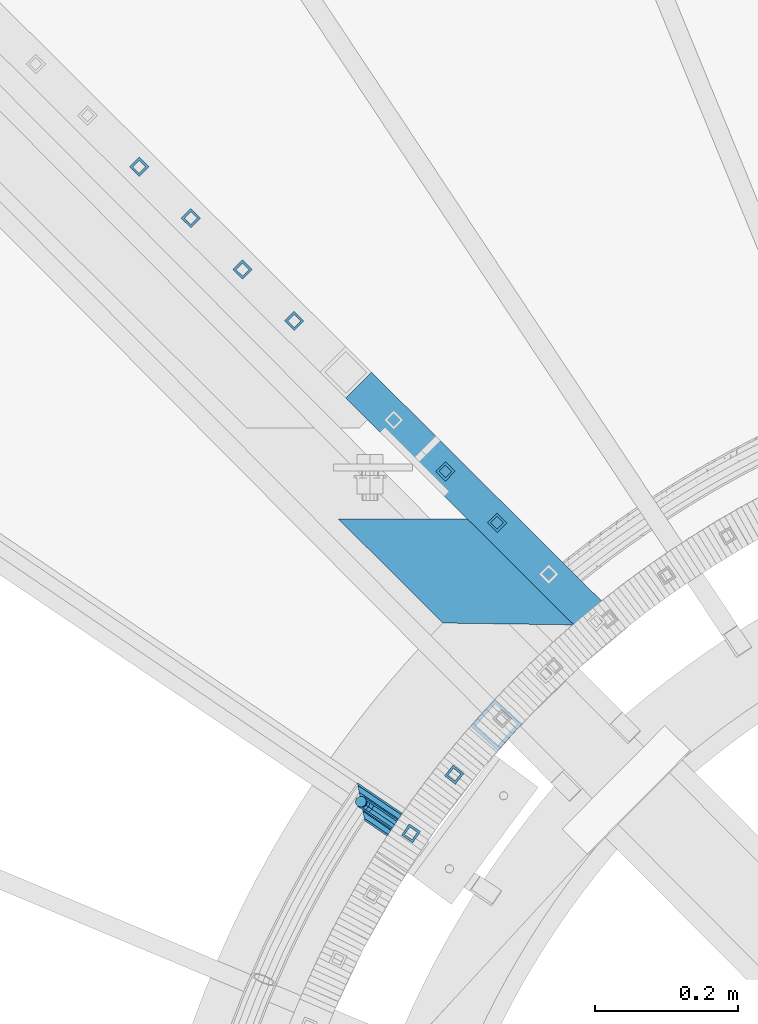
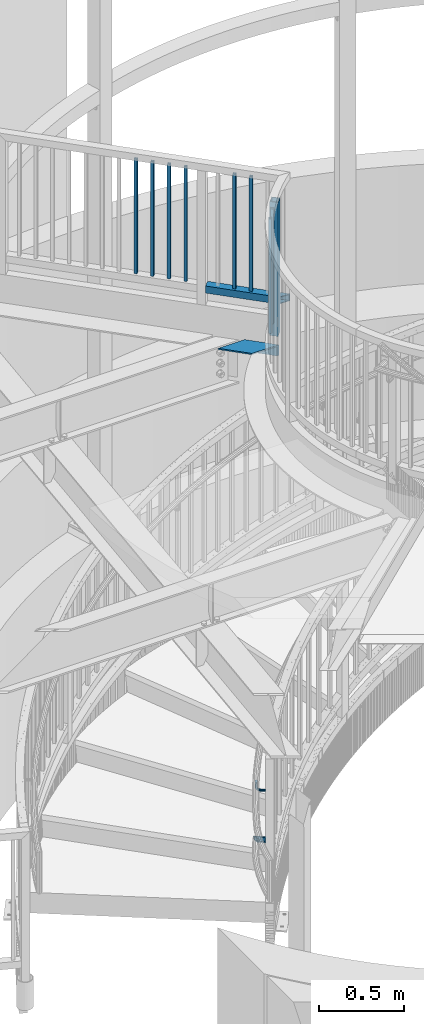
# One storey, part 482 of 975: 13 beams.
"""IFC2X3 building model written with IfcOpenShell, lengths in millimetres."""

import ifcopenshell
import ifcopenshell.guid

model = None  # the IFC model being written
_history = None  # IfcOwnerHistory: only IFC2X3 demands one
_inside = {}  # id of a spatial element -> (the spatial element, [elements in it])
_under = {}  # id of a project, library or spatial element -> (it, [spatial elements below it])
_declared = {}  # id of a project -> (the project, [libraries it declares])
_typed = {}  # id of a type object -> (the type object, [elements of that type])
_made_of = {}  # id of a material, layer set ... -> (it, [elements and type objects made of it])


def new_model(schema):
    """Start an empty IFC model of exactly this schema.

    Asked for "IFC4X3", IfcOpenShell would pick the latest addendum, in which some entities
    have other attributes; the version numbers below select the first issue.
    IFC2X3 requires an IfcOwnerHistory on every rooted entity: one is made here for all.
    """
    global model, _history
    if schema == "IFC4X3":
        model = ifcopenshell.file(schema_version=(4, 3, 0, 0))
    else:
        model = ifcopenshell.file(schema=schema)
    _inside.clear()
    _under.clear()
    _declared.clear()
    _typed.clear()
    _made_of.clear()
    _history = None
    if model.schema == "IFC2X3":
        org = make("IfcOrganization", Name="unknown")
        user = make(
            "IfcPersonAndOrganization",
            ThePerson=make("IfcPerson", FamilyName="unknown"),
            TheOrganization=org,
        )
        app = make(
            "IfcApplication",
            ApplicationDeveloper=org,
            Version="unknown",
            ApplicationFullName="unknown",
            ApplicationIdentifier="unknown",
        )
        _history = make(
            "IfcOwnerHistory",
            OwningUser=user,
            OwningApplication=app,
            ChangeAction="ADDED",
            CreationDate=0,
        )
    return model


def make(cls, **values):
    """One entity of the class cls with the attributes given. An attribute that is None is left unset."""
    return model.create_entity(
        cls, **{name: value for name, value in values.items() if value is not None}
    )


def rooted(cls, **values):
    """An entity with a GlobalId (a new one), such as an element, a storey or a relation."""
    return make(cls, GlobalId=ifcopenshell.guid.new(), OwnerHistory=_history, **values)


def si_unit(unit_type, name, prefix=None):
    """IfcSIUnit, for example si_unit("LENGTHUNIT", "METRE", prefix="MILLI")."""
    return make("IfcSIUnit", UnitType=unit_type, Prefix=prefix, Name=name)


def assignment(units):
    """IfcUnitAssignment: the units of a project."""
    return None if units is None else make("IfcUnitAssignment", Units=units)


def point(xyz):
    """IfcCartesianPoint."""
    return None if xyz is None else make("IfcCartesianPoint", Coordinates=xyz)


def direction(xyz):
    """IfcDirection."""
    return None if xyz is None else make("IfcDirection", DirectionRatios=xyz)


def frame(location, z_axis=None, x_axis=None):
    """IfcAxis2Placement3D, a coordinate frame: its origin and axes. An axis left out is left unset."""
    return make(
        "IfcAxis2Placement3D",
        Location=point(location),
        Axis=direction(z_axis),
        RefDirection=direction(x_axis),
    )


def origin_with_axes():
    """The frame at (0, 0, 0) with the z axis (0, 0, 1) and the x axis (1, 0, 0) written out."""
    return frame((0.0, 0.0, 0.0), z_axis=(0.0, 0.0, 1.0), x_axis=(1.0, 0.0, 0.0))


def place(relative_to, where):
    """IfcLocalPlacement: puts the frame where relative to a parent placement (None: the world)."""
    return make(
        "IfcLocalPlacement", PlacementRelTo=relative_to, RelativePlacement=where
    )


def context(
    kind, dimensions, precision=None, world=None, true_north=None, identifier=None
):
    """IfcGeometricRepresentationContext, for example the 3D "Model" context."""
    return make(
        "IfcGeometricRepresentationContext",
        ContextIdentifier=identifier,
        ContextType=kind,
        CoordinateSpaceDimension=dimensions,
        Precision=precision,
        WorldCoordinateSystem=world,
        TrueNorth=true_north,
    )


def subcontext(parent, identifier, kind, view, scale=None):
    """IfcGeometricRepresentationSubContext, for example "Body" below "Model"."""
    return make(
        "IfcGeometricRepresentationSubContext",
        ContextIdentifier=identifier,
        ContextType=kind,
        ParentContext=parent,
        TargetScale=scale,
        TargetView=view,
    )


def project(units=None, contexts=None):
    """IfcProject with its units and contexts."""
    return rooted(
        "IfcProject",
        Name="project",
        RepresentationContexts=contexts,
        UnitsInContext=assignment(units),
    )


def spatial(cls, under=None, at=None, **own):
    """A site, building, storey or space (cls), placed at a placement, below another one or the project."""
    s = rooted(cls, ObjectPlacement=at, **own)
    if under is not None:
        _under.setdefault(under.id(), (under, []))[1].append(s)
    return s


def faces_of(points, faces, orient=None, outer=None):
    """IfcFace entities. A face is a list of loops; a loop is a list of indices into points, from 0.

    orient and outer hold one flag for each loop. By default every Orientation is true, the
    first loop of a face is its IfcFaceOuterBound and the others are IfcFaceBound.
    """
    made = []
    for i, loops in enumerate(faces):
        bounds = []
        for j, loop in enumerate(loops):
            is_outer = j == 0 if outer is None else outer[i][j]
            bounds.append(
                make(
                    "IfcFaceOuterBound" if is_outer else "IfcFaceBound",
                    Bound=make("IfcPolyLoop", Polygon=[points[k] for k in loop]),
                    Orientation=True if orient is None else orient[i][j],
                )
            )
        made.append(make("IfcFace", Bounds=bounds))
    return made


def faceted_brep(points, faces, orient=None, outer=None, voids=None):
    """IfcFacetedBrep: a solid bounded by flat faces; with voids (closed shells), ...WithVoids."""
    shared = [point(p) for p in points]
    hull = make("IfcClosedShell", CfsFaces=faces_of(shared, faces, orient, outer))
    if voids is None:
        return make("IfcFacetedBrep", Outer=hull)
    return make(
        "IfcFacetedBrepWithVoids",
        Outer=hull,
        Voids=[
            make(cls, CfsFaces=faces_of(shared, fs, o, b)) for cls, fs, o, b in voids
        ],
    )


def shape(context_of_items, identifier, shape_type, items):
    """IfcShapeRepresentation: the items that make up one representation, for example the "Body"."""
    return make(
        "IfcShapeRepresentation",
        ContextOfItems=context_of_items,
        RepresentationIdentifier=identifier,
        RepresentationType=shape_type,
        Items=items,
    )


def material(Name=None, Category=None):
    """IfcMaterial."""
    return make("IfcMaterial", Name=Name, Category=Category)


def made_of(thing, what):
    """Note that an element or type object is made of a material, layer set ...; save() writes the relation."""
    if what is not None:
        _made_of.setdefault(what.id(), (what, []))[1].append(thing)
    return thing


def type_object(cls, material=None, **own):
    """A type object (cls), such as IfcWallType, which elements share."""
    return made_of(rooted(cls, **own), material)


def element(
    cls,
    number,
    at=None,
    inside=None,
    cuts=None,
    type_object=None,
    material=None,
    context=None,
    identifier="Body",
    shape_type=None,
    held_by="IfcProductDefinitionShape",
    body=None,
    shapes=None,
    **own,
):
    """One element of the class cls, such as IfcWall. Its Tag is "e" and its number.

    at: its placement. inside: the storey or other place that contains it. cuts: it is an
    opening in that element (IfcRelVoidsElement). A single representation is given by context,
    identifier, shape_type and body (its items); several are given by shapes. held_by: the class
    of the entity that holds the representations. save() writes the other relations.
    """
    e = rooted(cls, Tag="e%d" % number, ObjectPlacement=at, **own)
    if body is not None:
        shapes = [shape(context, identifier, shape_type, body)]
    if shapes is not None:
        e.Representation = make(held_by, Representations=shapes)
    if inside is not None:
        _inside.setdefault(inside.id(), (inside, []))[1].append(e)
    if cuts is not None:
        rooted(
            "IfcRelVoidsElement", RelatingBuildingElement=cuts, RelatedOpeningElement=e
        )
    if type_object is not None:
        _typed.setdefault(type_object.id(), (type_object, []))[1].append(e)
    return made_of(e, material)


def aggregate(whole, parts):
    """IfcRelAggregates: a whole, such as a stair, and the parts it consists of."""
    return rooted("IfcRelAggregates", RelatingObject=whole, RelatedObjects=parts)


def save(model, path):
    """Write the relations noted so far, then the file.

    IfcRelAggregates (storeys below a building ...), IfcRelContainedInSpatialStructure (elements
    in a storey), IfcRelDefinesByType, IfcRelAssociatesMaterial and IfcRelDeclares: one each for
    every whole, place, type object, material and project.
    """
    for whole, parts in _under.values():
        aggregate(whole, parts)
    for where, things in _inside.values():
        rooted(
            "IfcRelContainedInSpatialStructure",
            RelatedElements=things,
            RelatingStructure=where,
        )
    for kind, things in _typed.values():
        rooted("IfcRelDefinesByType", RelatedObjects=things, RelatingType=kind)
    for what, things in _made_of.values():
        rooted("IfcRelAssociatesMaterial", RelatedObjects=things, RelatingMaterial=what)
    for by, libraries in _declared.values():
        rooted("IfcRelDeclares", RelatingContext=by, RelatedDefinitions=libraries)
    model.write(path)


model = new_model("IFC2X3")

# Units and contexts
model_context = context("Model", 3, precision=1e-05, world=origin_with_axes())
body_context = subcontext(model_context, "Body", "Model", "MODEL_VIEW")
ifc_project = project(units=[si_unit("LENGTHUNIT", "METRE", prefix="MILLI"), si_unit("AREAUNIT", "SQUARE_METRE"), si_unit("VOLUMEUNIT", "CUBIC_METRE"), si_unit("MASSUNIT", "GRAM", prefix="KILO"), si_unit("TIMEUNIT", "SECOND"), si_unit("PLANEANGLEUNIT", "RADIAN"), si_unit("SOLIDANGLEUNIT", "STERADIAN"), si_unit("THERMODYNAMICTEMPERATUREUNIT", "DEGREE_CELSIUS"), si_unit("LUMINOUSINTENSITYUNIT", "LUMEN")], contexts=[model_context])

# Site, building, storey
site_placement = place(None, origin_with_axes())
site = spatial("IfcSite", under=ifc_project, at=site_placement, CompositionType="ELEMENT")
building_placement = place(site_placement, origin_with_axes())
building = spatial("IfcBuilding", under=site, at=building_placement, Name="Undefined", CompositionType="ELEMENT")
storey_placement = place(building_placement, origin_with_axes())
storey = spatial("IfcBuildingStorey", under=building, at=storey_placement, Name="Undefined", CompositionType="ELEMENT", Elevation=0.0)

# Beams
ifc_material_1 = material(Name="STEEL/A36")
beam_type_1 = type_object("IfcBeamType", PredefinedType="NOTDEFINED")
beam_1_placement = place(storey_placement, frame((33557.7032702106, 4202.58137412139, 983.976197247805), z_axis=(0.0, 0.0, 1.0), x_axis=(-0.825904005909728, 0.563810759938354, 0.0)))
element("IfcBeam", 1, at=beam_1_placement, inside=storey, type_object=beam_type_1, material=ifc_material_1, Name="BRACKET", context=body_context, shape_type="Brep", body=[
    faceted_brep([(-4.22995071858168e-07, -7.93750000000728, 0.0), (-2.99107341561466e-07, -5.61266007567065, -5.61266007566792), (31.7501749944095, -5.61266176762365, -5.61266007566792), (31.7501748705254, -7.93750169196028, 0.0), (-1.09139364212751e-11, 1.81898940354586e-12, -7.9375), (31.7501752935095, -1.69195118360221e-06, -7.9375), (2.99089151667431e-07, 5.61266007567428, -5.61266007566792), (31.7501755926023, 5.61265838372674, -5.61266007566792), (4.22980519942939e-07, 7.93750000001091, 0.0), (31.75017571649, 7.93749830806155, 0.0), (2.99089151667431e-07, 5.61266007567428, 5.61266007566792), (31.7501755926023, 5.61265838372674, 5.61266007566792), (-1.09139364212751e-11, 1.81898940354586e-12, 7.9375), (31.7501752935095, -1.69195118360221e-06, 7.9375), (-2.99107341561466e-07, -5.61266007567065, 5.61266007566792), (31.7501749944095, -5.61266176762365, 5.61266007566792), (44.5078840739552, -2.37179847317748e-06, -5.39983394413412), (43.6182060529281, -5.61266240006626, -3.2519619216755), (41.4703339065854, -7.93750220993934, 1.93345984517509), (39.3224620080255, -5.61266217115008, 7.11888161202842), (38.4327845851803, -2.0480601961026e-06, 9.26675363448339), (39.3224626062183, 5.61265798020031, 7.11888161202842), (41.4703347525501, 7.93749779008067, 1.93345984517509), (43.6182066511174, 5.61265775128231, -3.25196192167823), (53.6794375649406, 5.61265721512609, 3.47073764613469), (55.3233473415094, -2.94815072265919e-06, 1.82682757046678), (49.7106876888392, 7.93749735095298, 7.43948764613469), (45.7419375649588, 5.61265763811389, 11.4082376461338), (44.0980271902044, -2.34995968639851e-06, 13.0521477218017), (45.7419369667659, -5.6126625132365, 11.4082376461338), (49.7106868428746, -7.93750264906703, 7.43948764613469), (53.6794369667477, -5.6126629362243, 3.47073764613469), (60.402137132729, 5.61265685687795, 13.5319685599879), (62.5500088560802, -3.3332562452415e-06, 12.6422908380455), (55.2167154897834, 7.93749705753908, 15.6798405824429), (50.0312935990514, 5.61265740953786, 17.827712604897), (47.8834212775073, -2.55168015428353e-06, 18.7173903268394), (50.0312930008622, -5.61266274181617, 17.827712604897), (55.2167146438078, -7.93750294247729, 15.6798405824429), (60.4021365345397, -5.61266329447426, 13.5319685599879), (62.7628352867068, 5.61265673108028, 25.3999996185303), (65.0876749119416, -3.46848719345871e-06, 25.3999996185303), (57.1501753349476, 7.9374969545097, 25.3999996185303), (51.5375151354019, 5.6126573292695, 25.3999996185303), (49.2126749119889, -2.62251523963641e-06, 25.3999996185303), (51.5375145372127, -5.61266282207907, 25.3999996185303), (57.1501744889792, -7.93750304551213, 25.3999996185303), (62.762834688514, -5.61266342027193, 25.3999996185303), (65.0876746013255, -1.73646549228579e-06, 63.5120221482312), (62.7628345272369, -5.61266175011042, 66.9938536486543), (57.1501743895406, -7.93750152469875, 68.4290328748248), (51.5375143759102, -5.61266145062473, 66.9768513004874), (49.2126746013382, -1.31293927552179e-06, 63.4879771968608), (51.537514675425, 5.61265870070201, 60.0061456964377), (57.1501748131213, 7.93749847529398, 58.5709664702672), (62.7628348267535, 5.6126584012236, 60.0231480446046)], [[[0, 1, 2, 3]], [[1, 4, 5, 2]], [[4, 6, 7, 5]], [[6, 8, 9, 7]], [[8, 10, 11, 9]], [[10, 12, 13, 11]], [[12, 14, 15, 13]], [[14, 0, 3, 15]], [[14, 12, 10, 8, 6, 4, 1, 0]], [[2, 5, 16, 17]], [[3, 2, 17, 18]], [[15, 3, 18, 19]], [[13, 15, 19, 20]], [[11, 13, 20, 21]], [[9, 11, 21, 22]], [[7, 9, 22, 23]], [[5, 7, 23, 16]], [[23, 24, 25, 16]], [[22, 26, 24, 23]], [[21, 27, 26, 22]], [[20, 28, 27, 21]], [[19, 29, 28, 20]], [[18, 30, 29, 19]], [[17, 31, 30, 18]], [[16, 25, 31, 17]], [[24, 32, 33, 25]], [[26, 34, 32, 24]], [[27, 35, 34, 26]], [[28, 36, 35, 27]], [[29, 37, 36, 28]], [[30, 38, 37, 29]], [[31, 39, 38, 30]], [[25, 33, 39, 31]], [[32, 40, 41, 33]], [[34, 42, 40, 32]], [[35, 43, 42, 34]], [[36, 44, 43, 35]], [[37, 45, 44, 36]], [[38, 46, 45, 37]], [[39, 47, 46, 38]], [[33, 41, 47, 39]], [[47, 41, 48, 49]], [[46, 47, 49, 50]], [[45, 46, 50, 51]], [[44, 45, 51, 52]], [[43, 44, 52, 53]], [[42, 43, 53, 54]], [[40, 42, 54, 55]], [[41, 40, 55, 48]], [[54, 53, 52, 51, 50, 49, 48, 55]]]),
])
ifc_material_2 = material()
beam_type_2 = type_object("IfcBeamType", PredefinedType="NOTDEFINED")
beam_2_placement = place(storey_placement, frame((33492.6800295269, 4246.90986529355, 628.65), z_axis=(0.561796195996075, 0.827275669994192, 0.0), x_axis=(0.827275669994192, -0.561796195996076, 0.0)))
element("IfcBeam", 2, at=beam_2_placement, inside=storey, type_object=beam_type_2, material=ifc_material_2, Name="HANDRAIL", context=body_context, shape_type="Brep", body=[
    faceted_brep([(21.8582853410662, -15.367, 1.09139364212751e-11), (14.1195383126324, -13.3082123799554, 7.68350000000282), (78.6957079794083, -13.3082123799554, 7.6835000000392), (78.6957224495673, -15.367, 4.36557456851006e-11), (8.45438230088621, -7.68349999999998, 13.3082123799468), (78.6956973865163, -7.68349999999998, 13.3082123799941), (6.38079128418758, 0.0, 15.3669999999875), (78.695693509253, 0.0, 15.3670000000347), (8.45438230088621, 7.68349999999998, 13.3082123799468), (78.6956973865163, 7.68349999999998, 13.3082123799941), (14.1195383126324, 13.3082123799554, 7.68350000000282), (78.6957079794083, 13.3082123799554, 7.6835000000392), (21.8582853410662, 15.367, 1.09139364212751e-11), (78.6957224495673, 15.367, 4.36557456851006e-11), (29.597032369511, 13.3082123799554, -7.68349999997736), (78.6957369197189, 13.3082123799554, -7.68349999994825), (35.2621883812571, 7.68349999999998, -13.308212379925), (78.695747512611, 7.68349999999998, -13.3082123798995), (37.3357793979558, 0.0, -15.366999999962), (78.6957513898851, 0.0, -15.3669999999365), (35.2621883812571, -7.68349999999998, -13.308212379925), (78.695747512611, -7.68349999999998, -13.3082123798995), (29.597032369511, -13.3082123799554, -7.68349999997736), (78.6957369197189, -13.3082123799554, -7.68349999994825), (21.8582853410662, -19.05, 1.09139364212751e-11), (31.4517733928551, -16.4977839420935, -9.52499999997599), (78.695740387775, -16.4977839420935, -9.52499999994689), (78.6957224495673, -19.05, 4.36557456851006e-11), (38.4746940685727, -9.52499999999998, -16.4977839420571), (78.6957535194597, -9.52499999999998, -16.4977839420317), (41.045261444644, 0.0, -19.0499999999593), (78.6957583259864, 0.0, -19.0499999999374), (38.4746940685727, 9.52499999999998, -16.4977839420571), (78.6957535194597, 9.52499999999998, -16.4977839420317), (31.4517733928551, 16.4977839420935, -9.52499999997599), (78.695740387775, 16.4977839420935, -9.52499999994689), (21.8582853410662, 19.05, 1.09139364212751e-11), (78.6957224495673, 19.05, 4.36557456851006e-11), (12.2647972892846, 16.4977839420935, 9.52499999999782), (78.6957045113522, 16.4977839420935, 9.52500000003783), (5.24187661357064, 9.52499999999998, 16.497783942079), (78.6956913796676, 9.52499999999998, 16.4977839421226), (2.67130923749573, 0.0, 19.0499999999811), (78.6956865731408, 0.0, 19.0500000000284), (5.24187661357064, -9.52499999999998, 16.497783942079), (78.6956913796676, -9.52499999999998, 16.4977839421226), (12.2647972892846, -16.4977839420935, 9.52499999999782), (78.6957045113522, -16.4977839420935, 9.52500000003783)], [[[0, 1, 2, 3]], [[1, 4, 5, 2]], [[4, 6, 7, 5]], [[6, 8, 9, 7]], [[8, 10, 11, 9]], [[10, 12, 13, 11]], [[12, 14, 15, 13]], [[14, 16, 17, 15]], [[16, 18, 19, 17]], [[18, 20, 21, 19]], [[20, 22, 23, 21]], [[22, 0, 3, 23]], [[24, 25, 26, 27]], [[25, 28, 29, 26]], [[28, 30, 31, 29]], [[30, 32, 33, 31]], [[32, 34, 35, 33]], [[34, 36, 37, 35]], [[36, 38, 39, 37]], [[38, 40, 41, 39]], [[40, 42, 43, 41]], [[42, 44, 45, 43]], [[44, 46, 47, 45]], [[46, 24, 27, 47]], [[29, 31, 33, 35, 37, 39, 41, 43, 45, 47, 27, 26], [5, 7, 9, 11, 13, 15, 17, 19, 21, 23, 3, 2]], [[46, 44, 42, 40, 38, 36, 34, 32, 30, 28, 25, 24], [22, 20, 18, 16, 14, 12, 10, 8, 6, 4, 1, 0]]]),
])
beam_type_3 = type_object("IfcBeamType", Name="HSS3/4X3/4X.120_TUBES", PredefinedType="NOTDEFINED")
for number, where, z_axis, x_axis, name in (
    (3, (33628.3907372157, 4695.31378972424, 4279.9), (-0.708992011834517, 0.705216510835392, 0.0), (0.0, 0.0, 1.0), "PICKET"),
    (4, (33700.4243256199, 4623.66379222226, 4279.9), (-0.708992011834517, 0.705216510835392, 0.0), (0.0, 0.0, 1.0), "PICKET"),
    (5, (33201.3765192323, 5120.054085604, 4279.9), (-0.708992011834517, 0.705216510835392, 0.0), (0.0, 0.0, 1.0), "PICKET"),
    (6, (33273.4101076354, 5048.40408810286, 4279.9), (-0.708992011834517, 0.705216510835392, 0.0), (0.0, 0.0, 1.0), "PICKET"),
    (7, (33345.4436960385, 4976.75409060172, 4279.9), (-0.708992011834517, 0.705216510835392, 0.0), (0.0, 0.0, 1.0), "PICKET"),
    (8, (33417.4772844414, 4905.10409310073, 4279.9), (-0.708992011834517, 0.705216510835392, 0.0), (0.0, 0.0, 1.0), "PICKET"),
    (9, (33640.5738097518, 4272.3716555141, 4279.9), (-0.783038635883255, 0.621973065907271, 0.0), (0.0, 0.0, 1.0), "PICKET"),
    (10, (33580.3382235077, 4190.60097962442, 4279.9), (-0.826163577995053, 0.563430334996628, 0.0), (0.0, 0.0, 1.0), "PICKET"),
):
    element("IfcBeam", number, at=place(storey_placement, frame(where, z_axis=z_axis, x_axis=x_axis)), inside=storey, type_object=beam_type_3, material=ifc_material_2, Name=name, ObjectType="HSS3/4X3/4X.120_TUBES", context=body_context, shape_type="Brep", body=[
        faceted_brep([(0.0, 6.34999999998763, -6.34999999998763), (0.0, -6.35000000000582, -6.34999999998763), (825.49997943247, -6.35000000000582, -6.34999999998763), (825.49997943247, 6.34999999998763, -6.34999999998763), (0.0, -6.34999999998763, 6.34999999998763), (825.49997943247, -6.34999999998763, 6.34999999998763), (0.0, 6.35000000000946, 6.34999999998763), (825.49997943247, 6.35000000000946, 6.34999999998763), (0.0, 9.52499999997963, -9.52499999997963), (0.0, 9.52500000000873, 9.5249999999869), (825.49997943247, 9.52500000000873, 9.5249999999869), (825.49997943247, 9.52499999997963, -9.52499999997963), (0.0, -9.52499999997963, 9.52499999998327), (825.49997943247, -9.52499999997963, 9.52499999998327), (0.0, -9.52500000000873, -9.5249999999869), (825.49997943247, -9.52500000000873, -9.5249999999869)], [[[0, 1, 2, 3]], [[1, 4, 5, 2]], [[4, 6, 7, 5]], [[6, 0, 3, 7]], [[8, 9, 10, 11]], [[9, 12, 13, 10]], [[12, 14, 15, 13]], [[14, 8, 11, 15]], [[13, 15, 11, 10], [5, 7, 3, 2]], [[14, 12, 9, 8], [6, 4, 1, 0]]]),
    ])
beam_type_4 = type_object("IfcBeamType", Name="HSS2X2X.188_TUBES", PredefinedType="NOTDEFINED")
beam_3_placement = place(storey_placement, frame((33489.5108728508, 4833.45409559489, 4254.5), z_axis=(0.0, 0.0, 1.0), x_axis=(0.708992011834515, -0.705216510835394, 0.0)))
element("IfcBeam", 11, at=beam_3_placement, inside=storey, type_object=beam_type_4, material=ifc_material_2, Name="HANDRAIL", ObjectType="HSS2X2X.188_TUBES", context=body_context, shape_type="Brep", body=[
    faceted_brep([(25.3999997357314, 20.6374999999898, -20.6374999999998), (25.4000002641624, -20.6375000000153, -20.6374999999998), (478.185400323251, -20.6374999987966, -20.6374999999998), (523.696197160734, 20.6375000012231, -20.6374999999998), (25.4000002641624, -20.6375000000153, 20.6374999999998), (478.185400323251, -20.6374999987966, 20.6374999999998), (25.3999997357314, 20.6374999999898, 20.6374999999998), (523.696197160734, 20.6375000012231, 20.6374999999998), (25.4000003077635, 25.3999999999942, -25.3999999999996), (25.3999996747552, 25.3999999999905, 25.3999999999996), (528.947442949673, 25.4000000012238, 25.3999999999996), (528.947442949673, 25.4000000012238, -25.3999999999996), (25.4000003251349, -25.4000000000124, 25.3999999999996), (472.934154534309, -25.3999999988009, 25.3999999999996), (25.4000003077854, -25.4000000000087, -25.3999999999996), (472.934154534309, -25.3999999988009, -25.3999999999996)], [[[0, 1, 2, 3]], [[1, 4, 5, 2]], [[4, 6, 7, 5]], [[6, 0, 3, 7]], [[8, 9, 10, 11]], [[9, 12, 13, 10]], [[12, 14, 15, 13]], [[14, 8, 11, 15]], [[13, 15, 11, 10], [5, 7, 3, 2]], [[14, 12, 9, 8], [6, 4, 1, 0]]]),
])
beam_4_placement = place(storey_placement, frame((33699.2685057859, 4341.63238397214, 4140.2), z_axis=(-0.741039045801261, 0.671461936819919, 0.0), x_axis=(0.0, 0.0, 1.0)))
element("IfcBeam", 12, at=beam_4_placement, inside=storey, type_object=beam_type_4, material=ifc_material_2, Name="HANDRAIL", ObjectType="HSS2X2X.188_TUBES", context=body_context, shape_type="Brep", body=[
    faceted_brep([(0.0, 20.6374999999753, -20.6375000000298), (0.0, -20.6375000000153, -20.6375000000153), (965.200000000001, -20.6374999999025, -20.6375000000808), (965.200000000001, 20.637500000008, -20.637500000008), (0.0, -20.6374999999825, 20.6375000000335), (965.200000000001, -20.6375000000007, 20.6375000000116), (0.0, 20.6375000000116, 20.6375000000189), (965.200000000001, 20.6374999999061, 20.6375000000844), (0.0, 25.3999999999724, -25.4000000000342), (0.0, 25.400000000016, 25.4000000000196), (965.200000000001, 25.399999999885, 25.400000000107), (965.200000000001, 25.4000000000124, -25.4000000000124), (0.0, -25.399999999976, 25.4000000000378), (965.200000000001, -25.4000000000015, 25.4000000000124), (0.0, -25.400000000016, -25.4000000000196), (965.200000000001, -25.3999999998778, -25.4000000001033)], [[[0, 1, 2, 3]], [[1, 4, 5, 2]], [[4, 6, 7, 5]], [[6, 0, 3, 7]], [[8, 9, 10, 11]], [[9, 12, 13, 10]], [[12, 14, 15, 13]], [[14, 8, 11, 15]], [[13, 15, 11, 10], [5, 7, 3, 2]], [[14, 12, 9, 8], [6, 4, 1, 0]]]),
])
beam_type_5 = type_object("IfcBeamType", Name="L5X3X3/8", PredefinedType="NOTDEFINED")
beam_5_placement = place(storey_placement, frame((33474.9920122667, 4722.60448217439, 3898.9), z_axis=(-0.705338012987049, -0.708871135986987, 0.0), x_axis=(0.708871135986987, -0.705338012987049, 0.0)))
element("IfcBeam", 13, at=beam_5_placement, inside=storey, type_object=beam_type_5, material=ifc_material_1, Name="ANGLE", ObjectType="L5X3X3/8", context=body_context, shape_type="Brep", body=[
    faceted_brep([(274.652725947974, 28.5749999999998, 63.4999999994288), (396.068164820692, 28.5749999999998, -53.9750000008135), (396.068164820692, -38.0999999999999, -53.9750000008135), (405.912659864425, -38.0999999999999, -63.5000000008331), (405.912659864425, 38.0999999999999, -63.5000000008331), (274.652725947974, 38.0999999999999, 63.4999999994288), (196.314656782622, -38.0999999999999, -63.5000000004002), (196.314656782622, 38.0999999999999, -63.5000000004002), (68.6784984962906, 38.0999999999999, 63.4999999998436), (68.6784984962906, 28.5749999999998, 63.4999999998436), (186.741944911151, 28.5749999999998, -53.9750000003842), (186.741944911151, -38.0999999999999, -53.9750000003842)], [[[0, 1, 2, 3, 4, 5]], [[4, 3, 6, 7]], [[5, 4, 7, 8]], [[0, 5, 8, 9]], [[1, 0, 9, 10]], [[2, 1, 10, 11]], [[3, 2, 11, 6]], [[10, 9, 8, 7, 6, 11]]]),
])

save(model, "model.ifc")
